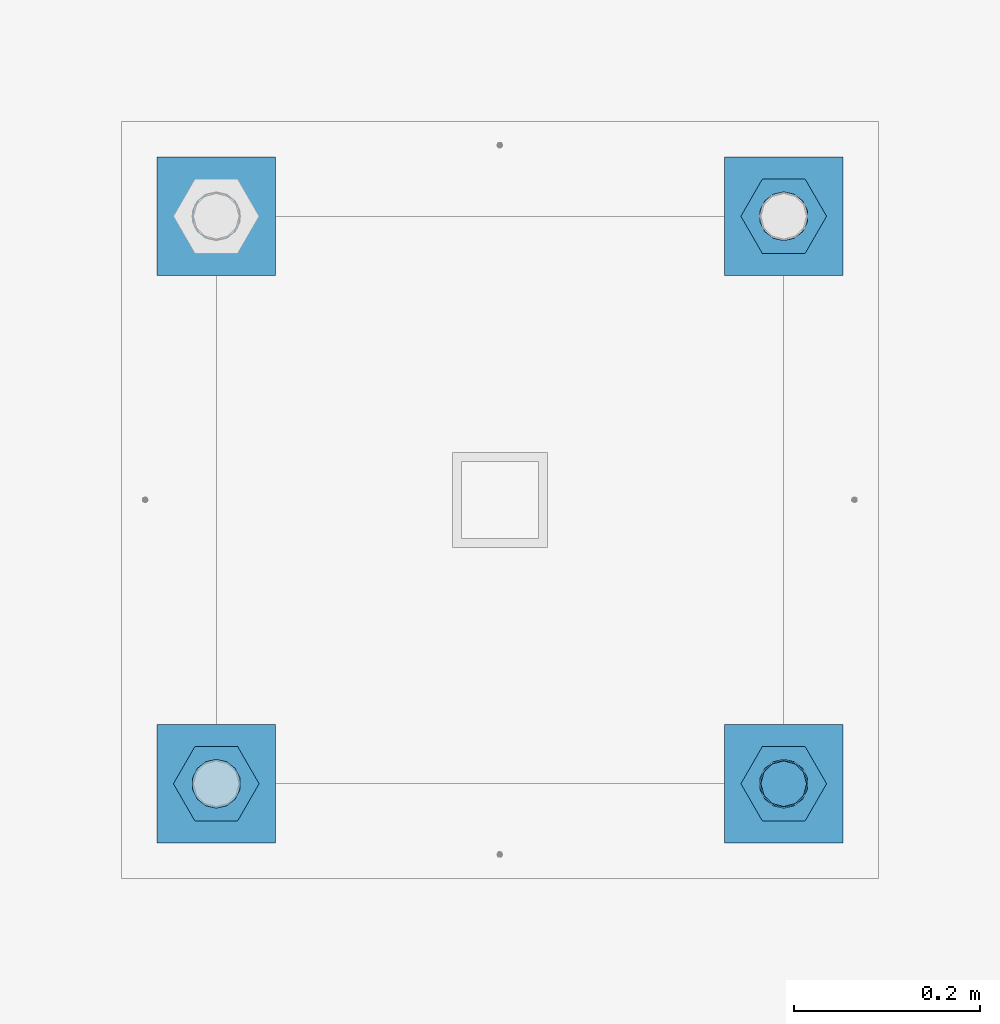
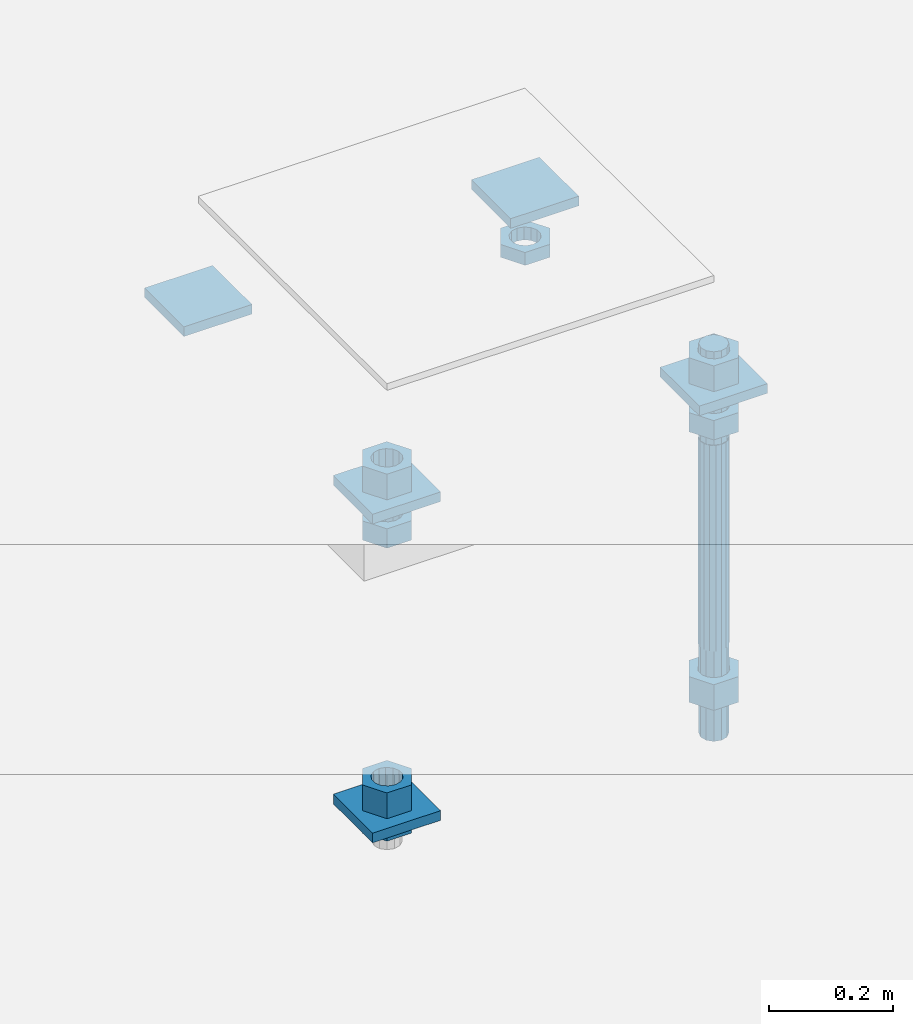
# One storey, part 2727 of 3843: 14 beams, 1 element without a shape of its own.
"""IFC2X3 building model written with IfcOpenShell, lengths in millimetres."""

from ifc_helpers import new_model, si_unit, frame, origin_with_axes, place, context, subcontext, project, spatial, faceted_brep, material, type_object, element, aggregate, save


model = new_model("IFC2X3")

# Units and contexts
model_context = context("Model", 3, precision=1e-05, world=origin_with_axes())
body_context = subcontext(model_context, "Body", "Model", "MODEL_VIEW")
ifc_project = project(units=[si_unit("LENGTHUNIT", "METRE", prefix="MILLI"), si_unit("AREAUNIT", "SQUARE_METRE"), si_unit("VOLUMEUNIT", "CUBIC_METRE"), si_unit("MASSUNIT", "GRAM", prefix="KILO"), si_unit("TIMEUNIT", "SECOND"), si_unit("PLANEANGLEUNIT", "RADIAN"), si_unit("SOLIDANGLEUNIT", "STERADIAN"), si_unit("THERMODYNAMICTEMPERATUREUNIT", "DEGREE_CELSIUS"), si_unit("LUMINOUSINTENSITYUNIT", "LUMEN")], contexts=[model_context])

# Site, building, storey
site_placement = place(None, origin_with_axes())
site = spatial("IfcSite", under=ifc_project, at=site_placement, CompositionType="ELEMENT")
building_placement = place(site_placement, origin_with_axes())
building = spatial("IfcBuilding", under=site, at=building_placement, Name="Undefined", CompositionType="ELEMENT")
storey_placement = place(building_placement, origin_with_axes())
storey = spatial("IfcBuildingStorey", under=building, at=storey_placement, Name="Undefined", CompositionType="ELEMENT", Elevation=0.0)

# Assembly, beams
assembly_placement = place(storey_placement, origin_with_axes())
assembly = element("IfcElementAssembly", 1, at=assembly_placement, inside=storey, Name="TEMPLATE", AssemblyPlace="NOTDEFINED", PredefinedType="RIGID_FRAME")
ifc_material_1 = material(Name="STEEL/A36")
beam_type_1 = type_object("IfcBeamType", PredefinedType="NOTDEFINED")
beam_1_placement = place(assembly_placement, frame((111734.6, 35750.5000015259, 29873.575), z_axis=(1.0, 0.0, 0.0), x_axis=(0.0, 1.0, 0.0)))
beam_1 = element("IfcBeam", 2, at=beam_1_placement, type_object=beam_type_1, material=ifc_material_1, Name="WASHER_PLATE", context=body_context, shape_type="Brep", body=[
    faceted_brep([(0.0, 9.52500000000146, -63.5), (0.0, 9.52500000000146, 63.5), (127.0, 9.52500000000146, 63.5), (127.0, 9.52500000000146, -63.5), (0.0, -9.52500000000146, 63.5), (127.0, -9.52500000000146, 63.5), (0.0, -9.52500000000146, -63.5), (127.0, -9.52500000000146, -63.5)], [[[0, 1, 2, 3]], [[1, 4, 5, 2]], [[4, 6, 7, 5]], [[6, 0, 3, 7]], [[5, 7, 3, 2]], [[6, 4, 1, 0]]]),
])
beam_2_placement = place(assembly_placement, frame((112344.2, 35750.5000015259, 29873.575), z_axis=(1.0, 0.0, 0.0), x_axis=(0.0, 1.0, 0.0)))
beam_2 = element("IfcBeam", 3, at=beam_2_placement, type_object=beam_type_1, material=ifc_material_1, Name="WASHER_PLATE", context=body_context, shape_type="Brep", body=[
    faceted_brep([(0.0, 9.52500000000146, -63.5), (0.0, 9.52500000000146, 63.5), (127.0, 9.52500000000146, 63.5), (127.0, 9.52500000000146, -63.5), (0.0, -9.52500000000146, 63.5), (127.0, -9.52500000000146, 63.5), (0.0, -9.52500000000146, -63.5), (127.0, -9.52500000000146, -63.5)], [[[0, 1, 2, 3]], [[1, 4, 5, 2]], [[4, 6, 7, 5]], [[6, 0, 3, 7]], [[5, 7, 3, 2]], [[6, 4, 1, 0]]]),
])
beam_3_placement = place(assembly_placement, frame((111734.6, 36360.1000015259, 29873.575), z_axis=(1.0, 0.0, 0.0), x_axis=(0.0, 1.0, 0.0)))
beam_3 = element("IfcBeam", 4, at=beam_3_placement, type_object=beam_type_1, material=ifc_material_1, Name="WASHER_PLATE", context=body_context, shape_type="Brep", body=[
    faceted_brep([(0.0, 9.52500000000146, -63.5), (0.0, 9.52500000000146, 63.5), (127.0, 9.52500000000146, 63.5), (127.0, 9.52500000000146, -63.5), (0.0, -9.52500000000146, 63.5), (127.0, -9.52500000000146, 63.5), (0.0, -9.52500000000146, -63.5), (127.0, -9.52500000000146, -63.5)], [[[0, 1, 2, 3]], [[1, 4, 5, 2]], [[4, 6, 7, 5]], [[6, 0, 3, 7]], [[5, 7, 3, 2]], [[6, 4, 1, 0]]]),
])
beam_4_placement = place(assembly_placement, frame((112344.2, 36360.1000015259, 29873.575), z_axis=(1.0, 0.0, 0.0), x_axis=(0.0, 1.0, 0.0)))
beam_4 = element("IfcBeam", 5, at=beam_4_placement, type_object=beam_type_1, material=ifc_material_1, Name="WASHER_PLATE", context=body_context, shape_type="Brep", body=[
    faceted_brep([(0.0, 9.52500000000146, -63.5), (0.0, 9.52500000000146, 63.5), (127.0, 9.52500000000146, 63.5), (127.0, 9.52500000000146, -63.5), (0.0, -9.52500000000146, 63.5), (127.0, -9.52500000000146, 63.5), (0.0, -9.52500000000146, -63.5), (127.0, -9.52500000000146, -63.5)], [[[0, 1, 2, 3]], [[1, 4, 5, 2]], [[4, 6, 7, 5]], [[6, 0, 3, 7]], [[5, 7, 3, 2]], [[6, 4, 1, 0]]]),
])
beam_5_placement = place(assembly_placement, frame((111734.6, 35750.5000015259, 29244.925), z_axis=(1.0, 0.0, 0.0), x_axis=(0.0, 1.0, 0.0)))
beam_5 = element("IfcBeam", 6, at=beam_5_placement, type_object=beam_type_1, material=ifc_material_1, Name="WASHER_PLATE", context=body_context, shape_type="Brep", body=[
    faceted_brep([(0.0, 9.52500000000146, -63.5), (0.0, 9.52500000000146, 63.5), (127.0, 9.52500000000146, 63.5), (127.0, 9.52500000000146, -63.5), (0.0, -9.52500000000146, 63.5), (127.0, -9.52500000000146, 63.5), (0.0, -9.52500000000146, -63.5), (127.0, -9.52500000000146, -63.5)], [[[0, 1, 2, 3]], [[1, 4, 5, 2]], [[4, 6, 7, 5]], [[6, 0, 3, 7]], [[5, 7, 3, 2]], [[6, 4, 1, 0]]]),
])
beam_type_2 = type_object("IfcBeamType", Name="2_HALF_NUT", PredefinedType="NOTDEFINED")
beam_6_placement = place(assembly_placement, frame((112344.2, 36423.6000015259, 29787.85), z_axis=(0.0, 1.0, 0.0), x_axis=(0.0, 0.0, -1.0)))
beam_6 = element("IfcBeam", 7, at=beam_6_placement, type_object=beam_type_2, material=ifc_material_1, Name="NUT", ObjectType="2_HALF_NUT", context=body_context, shape_type="Brep", body=[
    faceted_brep([(0.0, -46.0369987487793, 0.0), (0.0, -23.0184993743896, -39.869213104248), (25.4000000000015, -23.0184993743896, -39.869213104248), (25.4000000000015, -46.0369987487793, 0.0), (0.0, 23.0184993743896, -39.869213104248), (25.4000000000015, 23.0184993743896, -39.869213104248), (0.0, 46.0369987487793, 0.0), (25.4000000000015, 46.0369987487793, 0.0), (0.0, 23.0184993743896, 39.869213104248), (25.4000000000015, 23.0184993743896, 39.869213104248), (0.0, -23.0184993743896, 39.869213104248), (25.4000000000015, -23.0184993743896, 39.869213104248), (0.0, 0.0, 26.1940002441406), (0.0, 11.3650617044477, 23.5999013092805), (25.4000000000015, 11.3650617044477, 23.5999013092805), (25.4000000000015, 0.0, 26.1940002441406), (0.0, 20.4791109456419, 16.3316083006721), (25.4000000000015, 20.4791109456419, 16.3316083006721), (0.0, 25.5370200498292, 5.82867859874386), (25.4000000000015, 25.5370200498292, 5.82867859874386), (0.0, 25.5370200498292, -5.82867859874386), (25.4000000000015, 25.5370200498292, -5.82867859874386), (0.0, 20.4791109456419, -16.3316083006721), (25.4000000000015, 20.4791109456419, -16.3316083006721), (0.0, 11.3650617044477, -23.5999013092805), (25.4000000000015, 11.3650617044477, -23.5999013092805), (0.0, 0.0, -26.1940002441406), (25.4000000000015, 0.0, -26.1940002441406), (0.0, -11.3650617044477, -23.5999013092805), (25.4000000000015, -11.3650617044477, -23.5999013092805), (0.0, -20.4791109456419, -16.3316083006721), (25.4000000000015, -20.4791109456419, -16.3316083006721), (0.0, -25.5370200498292, -5.82867859874386), (25.4000000000015, -25.5370200498292, -5.82867859874386), (0.0, -25.5370200498292, 5.82867859874386), (25.4000000000015, -25.5370200498292, 5.82867859874386), (0.0, -20.4791109456419, 16.3316083006721), (25.4000000000015, -20.4791109456419, 16.3316083006721), (0.0, -11.3650617044477, 23.5999013092805), (25.4000000000015, -11.3650617044477, 23.5999013092805)], [[[0, 1, 2, 3]], [[1, 4, 5, 2]], [[4, 6, 7, 5]], [[6, 8, 9, 7]], [[8, 10, 11, 9]], [[10, 0, 3, 11]], [[12, 13, 14, 15]], [[13, 16, 17, 14]], [[16, 18, 19, 17]], [[18, 20, 21, 19]], [[20, 22, 23, 21]], [[22, 24, 25, 23]], [[24, 26, 27, 25]], [[26, 28, 29, 27]], [[28, 30, 31, 29]], [[30, 32, 33, 31]], [[32, 34, 35, 33]], [[34, 36, 37, 35]], [[36, 38, 39, 37]], [[38, 12, 15, 39]], [[5, 7, 9, 11, 3, 2], [17, 19, 21, 23, 25, 27, 29, 31, 33, 35, 37, 39, 15, 14]], [[10, 8, 6, 4, 1, 0], [38, 36, 34, 32, 30, 28, 26, 24, 22, 20, 18, 16, 13, 12]]]),
])
beam_7_placement = place(assembly_placement, frame((111734.6, 35814.0000015259, 29235.4), z_axis=(0.0, 1.0, 0.0), x_axis=(0.0, 0.0, -1.0)))
beam_7 = element("IfcBeam", 8, at=beam_7_placement, type_object=beam_type_2, material=ifc_material_1, Name="NUT", ObjectType="2_HALF_NUT", context=body_context, shape_type="Brep", body=[
    faceted_brep([(0.0, -46.0369987487793, 0.0), (0.0, -23.0184993743896, -39.869213104248), (25.4000000000015, -23.0184993743896, -39.869213104248), (25.4000000000015, -46.0369987487793, 0.0), (0.0, 23.0184993743896, -39.869213104248), (25.4000000000015, 23.0184993743896, -39.869213104248), (0.0, 46.0369987487793, 0.0), (25.4000000000015, 46.0369987487793, 0.0), (0.0, 23.0184993743896, 39.869213104248), (25.4000000000015, 23.0184993743896, 39.869213104248), (0.0, -23.0184993743896, 39.869213104248), (25.4000000000015, -23.0184993743896, 39.869213104248), (0.0, 0.0, 26.1940002441406), (0.0, 11.3650617044477, 23.5999013092805), (25.4000000000015, 11.3650617044477, 23.5999013092805), (25.4000000000015, 0.0, 26.1940002441406), (0.0, 20.4791109456419, 16.3316083006721), (25.4000000000015, 20.4791109456419, 16.3316083006721), (0.0, 25.5370200498292, 5.82867859874386), (25.4000000000015, 25.5370200498292, 5.82867859874386), (0.0, 25.5370200498292, -5.82867859874386), (25.4000000000015, 25.5370200498292, -5.82867859874386), (0.0, 20.4791109456419, -16.3316083006721), (25.4000000000015, 20.4791109456419, -16.3316083006721), (0.0, 11.3650617044477, -23.5999013092805), (25.4000000000015, 11.3650617044477, -23.5999013092805), (0.0, 0.0, -26.1940002441406), (25.4000000000015, 0.0, -26.1940002441406), (0.0, -11.3650617044477, -23.5999013092805), (25.4000000000015, -11.3650617044477, -23.5999013092805), (0.0, -20.4791109456419, -16.3316083006721), (25.4000000000015, -20.4791109456419, -16.3316083006721), (0.0, -25.5370200498292, -5.82867859874386), (25.4000000000015, -25.5370200498292, -5.82867859874386), (0.0, -25.5370200498292, 5.82867859874386), (25.4000000000015, -25.5370200498292, 5.82867859874386), (0.0, -20.4791109456419, 16.3316083006721), (25.4000000000015, -20.4791109456419, 16.3316083006721), (0.0, -11.3650617044477, 23.5999013092805), (25.4000000000015, -11.3650617044477, 23.5999013092805)], [[[0, 1, 2, 3]], [[1, 4, 5, 2]], [[4, 6, 7, 5]], [[6, 8, 9, 7]], [[8, 10, 11, 9]], [[10, 0, 3, 11]], [[12, 13, 14, 15]], [[13, 16, 17, 14]], [[16, 18, 19, 17]], [[18, 20, 21, 19]], [[20, 22, 23, 21]], [[22, 24, 25, 23]], [[24, 26, 27, 25]], [[26, 28, 29, 27]], [[28, 30, 31, 29]], [[30, 32, 33, 31]], [[32, 34, 35, 33]], [[34, 36, 37, 35]], [[36, 38, 39, 37]], [[38, 12, 15, 39]], [[5, 7, 9, 11, 3, 2], [17, 19, 21, 23, 25, 27, 29, 31, 33, 35, 37, 39, 15, 14]], [[10, 8, 6, 4, 1, 0], [38, 36, 34, 32, 30, 28, 26, 24, 22, 20, 18, 16, 13, 12]]]),
])
beam_type_3 = type_object("IfcBeamType", Name="2_HEAVY_HEX_NUT", PredefinedType="NOTDEFINED")
beam_8_placement = place(assembly_placement, frame((111734.6, 35814.0000015259, 29825.95), z_axis=(0.0, 1.0, 0.0), x_axis=(0.0, 0.0, -1.0)))
beam_8 = element("IfcBeam", 9, at=beam_8_placement, type_object=beam_type_3, material=ifc_material_1, Name="NUT", ObjectType="2_HEAVY_HEX_NUT", context=body_context, shape_type="Brep", body=[
    faceted_brep([(0.0, -46.0369987487793, 0.0), (0.0, -23.0184993743896, -39.869213104248), (38.0999999999985, -23.0184993743896, -39.869213104248), (38.0999999999985, -46.0369987487793, 0.0), (0.0, 23.0184993743896, -39.869213104248), (38.0999999999985, 23.0184993743896, -39.869213104248), (0.0, 46.0369987487793, 0.0), (38.0999999999985, 46.0369987487793, 0.0), (0.0, 23.0184993743896, 39.869213104248), (38.0999999999985, 23.0184993743896, 39.869213104248), (0.0, -23.0184993743896, 39.869213104248), (38.0999999999985, -23.0184993743896, 39.869213104248), (0.0, 0.0, 26.1940002441406), (0.0, 11.3650617044477, 23.5999013092805), (38.0999999999985, 11.3650617044477, 23.5999013092805), (38.0999999999985, 0.0, 26.1940002441406), (0.0, 20.4791109456419, 16.3316083006721), (38.0999999999985, 20.4791109456419, 16.3316083006721), (0.0, 25.5370200498292, 5.82867859874386), (38.0999999999985, 25.5370200498292, 5.82867859874386), (0.0, 25.5370200498292, -5.82867859874386), (38.0999999999985, 25.5370200498292, -5.82867859874386), (0.0, 20.4791109456419, -16.3316083006721), (38.0999999999985, 20.4791109456419, -16.3316083006721), (0.0, 11.3650617044477, -23.5999013092805), (38.0999999999985, 11.3650617044477, -23.5999013092805), (0.0, 0.0, -26.1940002441406), (38.0999999999985, 0.0, -26.1940002441406), (0.0, -11.3650617044477, -23.5999013092805), (38.0999999999985, -11.3650617044477, -23.5999013092805), (0.0, -20.4791109456419, -16.3316083006721), (38.0999999999985, -20.4791109456419, -16.3316083006721), (0.0, -25.5370200498292, -5.82867859874386), (38.0999999999985, -25.5370200498292, -5.82867859874386), (0.0, -25.5370200498292, 5.82867859874386), (38.0999999999985, -25.5370200498292, 5.82867859874386), (0.0, -20.4791109456419, 16.3316083006721), (38.0999999999985, -20.4791109456419, 16.3316083006721), (0.0, -11.3650617044477, 23.5999013092805), (38.0999999999985, -11.3650617044477, 23.5999013092805)], [[[0, 1, 2, 3]], [[1, 4, 5, 2]], [[4, 6, 7, 5]], [[6, 8, 9, 7]], [[8, 10, 11, 9]], [[10, 0, 3, 11]], [[12, 13, 14, 15]], [[13, 16, 17, 14]], [[16, 18, 19, 17]], [[18, 20, 21, 19]], [[20, 22, 23, 21]], [[22, 24, 25, 23]], [[24, 26, 27, 25]], [[26, 28, 29, 27]], [[28, 30, 31, 29]], [[30, 32, 33, 31]], [[32, 34, 35, 33]], [[34, 36, 37, 35]], [[36, 38, 39, 37]], [[38, 12, 15, 39]], [[5, 7, 9, 11, 3, 2], [17, 19, 21, 23, 25, 27, 29, 31, 33, 35, 37, 39, 15, 14]], [[10, 8, 6, 4, 1, 0], [38, 36, 34, 32, 30, 28, 26, 24, 22, 20, 18, 16, 13, 12]]]),
])
beam_9_placement = place(assembly_placement, frame((111734.6, 35814.0000015259, 29933.9), z_axis=(0.0, 1.0, 0.0), x_axis=(0.0, 0.0, -1.0)))
beam_9 = element("IfcBeam", 10, at=beam_9_placement, type_object=beam_type_3, material=ifc_material_1, Name="NUT", ObjectType="2_HEAVY_HEX_NUT", context=body_context, shape_type="Brep", body=[
    faceted_brep([(0.0, -46.0369987487793, 0.0), (0.0, -23.0184993743896, -39.869213104248), (50.7999999999993, -23.0184993743896, -39.869213104248), (50.7999999999993, -46.0369987487793, 0.0), (0.0, 23.0184993743896, -39.869213104248), (50.7999999999993, 23.0184993743896, -39.869213104248), (0.0, 46.0369987487793, 0.0), (50.7999999999993, 46.0369987487793, 0.0), (0.0, 23.0184993743896, 39.869213104248), (50.7999999999993, 23.0184993743896, 39.869213104248), (0.0, -23.0184993743896, 39.869213104248), (50.7999999999993, -23.0184993743896, 39.869213104248), (0.0, 0.0, 26.1940002441406), (0.0, 11.3650617044477, 23.5999013092805), (50.7999999999993, 11.3650617044477, 23.5999013092805), (50.7999999999993, 0.0, 26.1940002441406), (0.0, 20.4791109456419, 16.3316083006721), (50.7999999999993, 20.4791109456419, 16.3316083006721), (0.0, 25.5370200498292, 5.82867859874386), (50.7999999999993, 25.5370200498292, 5.82867859874386), (0.0, 25.5370200498292, -5.82867859874386), (50.7999999999993, 25.5370200498292, -5.82867859874386), (0.0, 20.4791109456419, -16.3316083006721), (50.7999999999993, 20.4791109456419, -16.3316083006721), (0.0, 11.3650617044477, -23.5999013092805), (50.7999999999993, 11.3650617044477, -23.5999013092805), (0.0, 0.0, -26.1940002441406), (50.7999999999993, 0.0, -26.1940002441406), (0.0, -11.3650617044477, -23.5999013092805), (50.7999999999993, -11.3650617044477, -23.5999013092805), (0.0, -20.4791109456419, -16.3316083006721), (50.7999999999993, -20.4791109456419, -16.3316083006721), (0.0, -25.5370200498292, -5.82867859874386), (50.7999999999993, -25.5370200498292, -5.82867859874386), (0.0, -25.5370200498292, 5.82867859874386), (50.7999999999993, -25.5370200498292, 5.82867859874386), (0.0, -20.4791109456419, 16.3316083006721), (50.7999999999993, -20.4791109456419, 16.3316083006721), (0.0, -11.3650617044477, 23.5999013092805), (50.7999999999993, -11.3650617044477, 23.5999013092805)], [[[0, 1, 2, 3]], [[1, 4, 5, 2]], [[4, 6, 7, 5]], [[6, 8, 9, 7]], [[8, 10, 11, 9]], [[10, 0, 3, 11]], [[12, 13, 14, 15]], [[13, 16, 17, 14]], [[16, 18, 19, 17]], [[18, 20, 21, 19]], [[20, 22, 23, 21]], [[22, 24, 25, 23]], [[24, 26, 27, 25]], [[26, 28, 29, 27]], [[28, 30, 31, 29]], [[30, 32, 33, 31]], [[32, 34, 35, 33]], [[34, 36, 37, 35]], [[36, 38, 39, 37]], [[38, 12, 15, 39]], [[5, 7, 9, 11, 3, 2], [17, 19, 21, 23, 25, 27, 29, 31, 33, 35, 37, 39, 15, 14]], [[10, 8, 6, 4, 1, 0], [38, 36, 34, 32, 30, 28, 26, 24, 22, 20, 18, 16, 13, 12]]]),
])
beam_10_placement = place(assembly_placement, frame((111734.6, 35814.0000015259, 29305.25), z_axis=(0.0, 1.0, 0.0), x_axis=(0.0, 0.0, -1.0)))
beam_10 = element("IfcBeam", 11, at=beam_10_placement, type_object=beam_type_3, material=ifc_material_1, Name="NUT", ObjectType="2_HEAVY_HEX_NUT", context=body_context, shape_type="Brep", body=[
    faceted_brep([(0.0, -46.0369987487793, 0.0), (0.0, -23.0184993743896, -39.869213104248), (50.7999999999993, -23.0184993743896, -39.869213104248), (50.7999999999993, -46.0369987487793, 0.0), (0.0, 23.0184993743896, -39.869213104248), (50.7999999999993, 23.0184993743896, -39.869213104248), (0.0, 46.0369987487793, 0.0), (50.7999999999993, 46.0369987487793, 0.0), (0.0, 23.0184993743896, 39.869213104248), (50.7999999999993, 23.0184993743896, 39.869213104248), (0.0, -23.0184993743896, 39.869213104248), (50.7999999999993, -23.0184993743896, 39.869213104248), (0.0, 0.0, 26.1940002441406), (0.0, 11.3650617044477, 23.5999013092805), (50.7999999999993, 11.3650617044477, 23.5999013092805), (50.7999999999993, 0.0, 26.1940002441406), (0.0, 20.4791109456419, 16.3316083006721), (50.7999999999993, 20.4791109456419, 16.3316083006721), (0.0, 25.5370200498292, 5.82867859874386), (50.7999999999993, 25.5370200498292, 5.82867859874386), (0.0, 25.5370200498292, -5.82867859874386), (50.7999999999993, 25.5370200498292, -5.82867859874386), (0.0, 20.4791109456419, -16.3316083006721), (50.7999999999993, 20.4791109456419, -16.3316083006721), (0.0, 11.3650617044477, -23.5999013092805), (50.7999999999993, 11.3650617044477, -23.5999013092805), (0.0, 0.0, -26.1940002441406), (50.7999999999993, 0.0, -26.1940002441406), (0.0, -11.3650617044477, -23.5999013092805), (50.7999999999993, -11.3650617044477, -23.5999013092805), (0.0, -20.4791109456419, -16.3316083006721), (50.7999999999993, -20.4791109456419, -16.3316083006721), (0.0, -25.5370200498292, -5.82867859874386), (50.7999999999993, -25.5370200498292, -5.82867859874386), (0.0, -25.5370200498292, 5.82867859874386), (50.7999999999993, -25.5370200498292, 5.82867859874386), (0.0, -20.4791109456419, 16.3316083006721), (50.7999999999993, -20.4791109456419, 16.3316083006721), (0.0, -11.3650617044477, 23.5999013092805), (50.7999999999993, -11.3650617044477, 23.5999013092805)], [[[0, 1, 2, 3]], [[1, 4, 5, 2]], [[4, 6, 7, 5]], [[6, 8, 9, 7]], [[8, 10, 11, 9]], [[10, 0, 3, 11]], [[12, 13, 14, 15]], [[13, 16, 17, 14]], [[16, 18, 19, 17]], [[18, 20, 21, 19]], [[20, 22, 23, 21]], [[22, 24, 25, 23]], [[24, 26, 27, 25]], [[26, 28, 29, 27]], [[28, 30, 31, 29]], [[30, 32, 33, 31]], [[32, 34, 35, 33]], [[34, 36, 37, 35]], [[36, 38, 39, 37]], [[38, 12, 15, 39]], [[5, 7, 9, 11, 3, 2], [17, 19, 21, 23, 25, 27, 29, 31, 33, 35, 37, 39, 15, 14]], [[10, 8, 6, 4, 1, 0], [38, 36, 34, 32, 30, 28, 26, 24, 22, 20, 18, 16, 13, 12]]]),
])
beam_11_placement = place(assembly_placement, frame((112344.2, 35814.0000015259, 29825.95), z_axis=(0.0, 1.0, 0.0), x_axis=(0.0, 0.0, -1.0)))
beam_11 = element("IfcBeam", 12, at=beam_11_placement, type_object=beam_type_3, material=ifc_material_1, Name="NUT", ObjectType="2_HEAVY_HEX_NUT", context=body_context, shape_type="Brep", body=[
    faceted_brep([(0.0, -46.0369987487793, 0.0), (0.0, -23.0184993743896, -39.869213104248), (38.0999999999985, -23.0184993743896, -39.869213104248), (38.0999999999985, -46.0369987487793, 0.0), (0.0, 23.0184993743896, -39.869213104248), (38.0999999999985, 23.0184993743896, -39.869213104248), (0.0, 46.0369987487793, 0.0), (38.0999999999985, 46.0369987487793, 0.0), (0.0, 23.0184993743896, 39.869213104248), (38.0999999999985, 23.0184993743896, 39.869213104248), (0.0, -23.0184993743896, 39.869213104248), (38.0999999999985, -23.0184993743896, 39.869213104248), (0.0, 0.0, 26.1940002441406), (0.0, 11.3650617044477, 23.5999013092805), (38.0999999999985, 11.3650617044477, 23.5999013092805), (38.0999999999985, 0.0, 26.1940002441406), (0.0, 20.4791109456419, 16.3316083006721), (38.0999999999985, 20.4791109456419, 16.3316083006721), (0.0, 25.5370200498292, 5.82867859874386), (38.0999999999985, 25.5370200498292, 5.82867859874386), (0.0, 25.5370200498292, -5.82867859874386), (38.0999999999985, 25.5370200498292, -5.82867859874386), (0.0, 20.4791109456419, -16.3316083006721), (38.0999999999985, 20.4791109456419, -16.3316083006721), (0.0, 11.3650617044477, -23.5999013092805), (38.0999999999985, 11.3650617044477, -23.5999013092805), (0.0, 0.0, -26.1940002441406), (38.0999999999985, 0.0, -26.1940002441406), (0.0, -11.3650617044477, -23.5999013092805), (38.0999999999985, -11.3650617044477, -23.5999013092805), (0.0, -20.4791109456419, -16.3316083006721), (38.0999999999985, -20.4791109456419, -16.3316083006721), (0.0, -25.5370200498292, -5.82867859874386), (38.0999999999985, -25.5370200498292, -5.82867859874386), (0.0, -25.5370200498292, 5.82867859874386), (38.0999999999985, -25.5370200498292, 5.82867859874386), (0.0, -20.4791109456419, 16.3316083006721), (38.0999999999985, -20.4791109456419, 16.3316083006721), (0.0, -11.3650617044477, 23.5999013092805), (38.0999999999985, -11.3650617044477, 23.5999013092805)], [[[0, 1, 2, 3]], [[1, 4, 5, 2]], [[4, 6, 7, 5]], [[6, 8, 9, 7]], [[8, 10, 11, 9]], [[10, 0, 3, 11]], [[12, 13, 14, 15]], [[13, 16, 17, 14]], [[16, 18, 19, 17]], [[18, 20, 21, 19]], [[20, 22, 23, 21]], [[22, 24, 25, 23]], [[24, 26, 27, 25]], [[26, 28, 29, 27]], [[28, 30, 31, 29]], [[30, 32, 33, 31]], [[32, 34, 35, 33]], [[34, 36, 37, 35]], [[36, 38, 39, 37]], [[38, 12, 15, 39]], [[5, 7, 9, 11, 3, 2], [17, 19, 21, 23, 25, 27, 29, 31, 33, 35, 37, 39, 15, 14]], [[10, 8, 6, 4, 1, 0], [38, 36, 34, 32, 30, 28, 26, 24, 22, 20, 18, 16, 13, 12]]]),
])
beam_12_placement = place(assembly_placement, frame((112344.2, 35814.0000015259, 29933.9), z_axis=(0.0, 1.0, 0.0), x_axis=(0.0, 0.0, -1.0)))
beam_12 = element("IfcBeam", 13, at=beam_12_placement, type_object=beam_type_3, material=ifc_material_1, Name="NUT", ObjectType="2_HEAVY_HEX_NUT", context=body_context, shape_type="Brep", body=[
    faceted_brep([(0.0, -46.0369987487793, 0.0), (0.0, -23.0184993743896, -39.869213104248), (50.7999999999993, -23.0184993743896, -39.869213104248), (50.7999999999993, -46.0369987487793, 0.0), (0.0, 23.0184993743896, -39.869213104248), (50.7999999999993, 23.0184993743896, -39.869213104248), (0.0, 46.0369987487793, 0.0), (50.7999999999993, 46.0369987487793, 0.0), (0.0, 23.0184993743896, 39.869213104248), (50.7999999999993, 23.0184993743896, 39.869213104248), (0.0, -23.0184993743896, 39.869213104248), (50.7999999999993, -23.0184993743896, 39.869213104248), (0.0, 0.0, 26.1940002441406), (0.0, 11.3650617044477, 23.5999013092805), (50.7999999999993, 11.3650617044477, 23.5999013092805), (50.7999999999993, 0.0, 26.1940002441406), (0.0, 20.4791109456419, 16.3316083006721), (50.7999999999993, 20.4791109456419, 16.3316083006721), (0.0, 25.5370200498292, 5.82867859874386), (50.7999999999993, 25.5370200498292, 5.82867859874386), (0.0, 25.5370200498292, -5.82867859874386), (50.7999999999993, 25.5370200498292, -5.82867859874386), (0.0, 20.4791109456419, -16.3316083006721), (50.7999999999993, 20.4791109456419, -16.3316083006721), (0.0, 11.3650617044477, -23.5999013092805), (50.7999999999993, 11.3650617044477, -23.5999013092805), (0.0, 0.0, -26.1940002441406), (50.7999999999993, 0.0, -26.1940002441406), (0.0, -11.3650617044477, -23.5999013092805), (50.7999999999993, -11.3650617044477, -23.5999013092805), (0.0, -20.4791109456419, -16.3316083006721), (50.7999999999993, -20.4791109456419, -16.3316083006721), (0.0, -25.5370200498292, -5.82867859874386), (50.7999999999993, -25.5370200498292, -5.82867859874386), (0.0, -25.5370200498292, 5.82867859874386), (50.7999999999993, -25.5370200498292, 5.82867859874386), (0.0, -20.4791109456419, 16.3316083006721), (50.7999999999993, -20.4791109456419, 16.3316083006721), (0.0, -11.3650617044477, 23.5999013092805), (50.7999999999993, -11.3650617044477, 23.5999013092805)], [[[0, 1, 2, 3]], [[1, 4, 5, 2]], [[4, 6, 7, 5]], [[6, 8, 9, 7]], [[8, 10, 11, 9]], [[10, 0, 3, 11]], [[12, 13, 14, 15]], [[13, 16, 17, 14]], [[16, 18, 19, 17]], [[18, 20, 21, 19]], [[20, 22, 23, 21]], [[22, 24, 25, 23]], [[24, 26, 27, 25]], [[26, 28, 29, 27]], [[28, 30, 31, 29]], [[30, 32, 33, 31]], [[32, 34, 35, 33]], [[34, 36, 37, 35]], [[36, 38, 39, 37]], [[38, 12, 15, 39]], [[5, 7, 9, 11, 3, 2], [17, 19, 21, 23, 25, 27, 29, 31, 33, 35, 37, 39, 15, 14]], [[10, 8, 6, 4, 1, 0], [38, 36, 34, 32, 30, 28, 26, 24, 22, 20, 18, 16, 13, 12]]]),
])
beam_13_placement = place(assembly_placement, frame((112344.2, 35814.0000015259, 29305.25), z_axis=(0.0, 1.0, 0.0), x_axis=(0.0, 0.0, -1.0)))
beam_13 = element("IfcBeam", 14, at=beam_13_placement, type_object=beam_type_3, material=ifc_material_1, Name="NUT", ObjectType="2_HEAVY_HEX_NUT", context=body_context, shape_type="Brep", body=[
    faceted_brep([(0.0, -46.0369987487793, 0.0), (0.0, -23.0184993743896, -39.869213104248), (50.7999999999993, -23.0184993743896, -39.869213104248), (50.7999999999993, -46.0369987487793, 0.0), (0.0, 23.0184993743896, -39.869213104248), (50.7999999999993, 23.0184993743896, -39.869213104248), (0.0, 46.0369987487793, 0.0), (50.7999999999993, 46.0369987487793, 0.0), (0.0, 23.0184993743896, 39.869213104248), (50.7999999999993, 23.0184993743896, 39.869213104248), (0.0, -23.0184993743896, 39.869213104248), (50.7999999999993, -23.0184993743896, 39.869213104248), (0.0, 0.0, 26.1940002441406), (0.0, 11.3650617044477, 23.5999013092805), (50.7999999999993, 11.3650617044477, 23.5999013092805), (50.7999999999993, 0.0, 26.1940002441406), (0.0, 20.4791109456419, 16.3316083006721), (50.7999999999993, 20.4791109456419, 16.3316083006721), (0.0, 25.5370200498292, 5.82867859874386), (50.7999999999993, 25.5370200498292, 5.82867859874386), (0.0, 25.5370200498292, -5.82867859874386), (50.7999999999993, 25.5370200498292, -5.82867859874386), (0.0, 20.4791109456419, -16.3316083006721), (50.7999999999993, 20.4791109456419, -16.3316083006721), (0.0, 11.3650617044477, -23.5999013092805), (50.7999999999993, 11.3650617044477, -23.5999013092805), (0.0, 0.0, -26.1940002441406), (50.7999999999993, 0.0, -26.1940002441406), (0.0, -11.3650617044477, -23.5999013092805), (50.7999999999993, -11.3650617044477, -23.5999013092805), (0.0, -20.4791109456419, -16.3316083006721), (50.7999999999993, -20.4791109456419, -16.3316083006721), (0.0, -25.5370200498292, -5.82867859874386), (50.7999999999993, -25.5370200498292, -5.82867859874386), (0.0, -25.5370200498292, 5.82867859874386), (50.7999999999993, -25.5370200498292, 5.82867859874386), (0.0, -20.4791109456419, 16.3316083006721), (50.7999999999993, -20.4791109456419, 16.3316083006721), (0.0, -11.3650617044477, 23.5999013092805), (50.7999999999993, -11.3650617044477, 23.5999013092805)], [[[0, 1, 2, 3]], [[1, 4, 5, 2]], [[4, 6, 7, 5]], [[6, 8, 9, 7]], [[8, 10, 11, 9]], [[10, 0, 3, 11]], [[12, 13, 14, 15]], [[13, 16, 17, 14]], [[16, 18, 19, 17]], [[18, 20, 21, 19]], [[20, 22, 23, 21]], [[22, 24, 25, 23]], [[24, 26, 27, 25]], [[26, 28, 29, 27]], [[28, 30, 31, 29]], [[30, 32, 33, 31]], [[32, 34, 35, 33]], [[34, 36, 37, 35]], [[36, 38, 39, 37]], [[38, 12, 15, 39]], [[5, 7, 9, 11, 3, 2], [17, 19, 21, 23, 25, 27, 29, 31, 33, 35, 37, 39, 15, 14]], [[10, 8, 6, 4, 1, 0], [38, 36, 34, 32, 30, 28, 26, 24, 22, 20, 18, 16, 13, 12]]]),
])
ifc_material_2 = material()
beam_type_4 = type_object("IfcBeamType", PredefinedType="NOTDEFINED")
beam_14_placement = place(assembly_placement, frame((112344.2, 35814.0000015259, 29762.45), z_axis=(0.0, 1.0, 0.0), x_axis=(0.0, 0.0, -1.0)))
beam_14 = element("IfcBeam", 15, at=beam_14_placement, type_object=beam_type_4, material=ifc_material_2, Name="ANCHOR_ROD", context=body_context, shape_type="Brep", body=[
    faceted_brep([(-184.150000000001, -21.217622392709, 12.25), (-184.150000000001, -12.2499999999854, 21.2176223927163), (-184.150000000001, 1.45519152283669e-11, 24.5), (-184.150000000001, 12.2500000000146, 21.2176223927163), (-184.150000000001, 21.2176223927381, 12.25), (-184.150000000001, 24.5000000000146, 0.0), (-184.150000000001, 21.2176223927381, -12.25), (-184.150000000001, 12.2500000000146, -21.2176223927163), (-184.150000000001, 1.45519152283669e-11, -24.5), (-184.150000000001, -12.2499999999854, -21.2176223927163), (-184.150000000001, -21.217622392709, -12.25), (-184.150000000001, -24.4999999999854, 0.0), (0.0, 24.5000000000146, 0.0), (0.0, 21.2176223927381, -12.25), (0.0, 12.2500000000146, -21.2176223927163), (0.0, 1.45519152283669e-11, -24.5), (0.0, -12.2499999999854, -21.2176223927163), (0.0, -21.217622392709, -12.25), (0.0, -24.4999999999854, 0.0), (0.0, -21.217622392709, 12.25), (0.0, -12.2499999999854, 21.2176223927163), (0.0, 1.45519152283669e-11, 24.5), (0.0, 12.2500000000146, 21.2176223927163), (0.0, 21.2176223927381, 12.25), (0.0, -23.4665401257807, 9.72015918207035), (0.0, -17.9605122421344, 17.9605122421417), (0.0, -9.72015918207762, 23.466540125788), (0.0, 0.0, 25.4000000000015), (0.0, 9.72015918207762, 23.466540125788), (0.0, 17.9605122421344, 17.9605122421417), (0.0, 23.4665401257807, 9.72015918207035), (0.0, 25.3999996185303, 0.0), (0.0, 23.4665401257807, -9.72015918207035), (0.0, 17.9605122421344, -17.9605122421417), (0.0, 9.72015918207762, -23.466540125788), (0.0, 0.0, -25.4000000000015), (0.0, -9.72015918207762, -23.466540125788), (0.0, -17.9605122421344, -17.9605122421417), (0.0, -23.4665401257807, -9.72015918207035), (0.0, -25.3999996185303, 0.0), (406.399999999998, -25.3999999999942, 0.0), (406.399999999998, -23.4665401257807, 9.72015918207035), (406.399999999998, -17.9605122421344, 17.9605122421417), (406.399999999998, -9.72015918207762, 23.466540125788), (406.399999999998, 0.0, 25.4000000000015), (406.399999999998, 9.72015918207762, 23.466540125788), (406.399999999998, 17.9605122421344, 17.9605122421417), (406.399999999998, 23.4665401257807, 9.72015918207035), (406.399999999998, 25.3999999999942, 0.0), (406.399999999998, 23.4665401257807, -9.72015918207035), (406.399999999998, 17.9605122421344, -17.9605122421417), (406.399999999998, 9.72015918207762, -23.466540125788), (406.399999999998, 0.0, -25.4000000000015), (406.399999999998, -9.72015918207762, -23.466540125788), (406.399999999998, -17.9605122421344, -17.9605122421417), (406.399999999998, -23.4665401257807, -9.72015918207035), (406.399999999998, -12.2499999999854, 21.2176223927163), (406.399999999998, 1.45519152283669e-11, 24.5), (406.399999999998, 12.2500000000146, 21.2176223927163), (406.399999999998, 21.2176223927381, 12.25), (406.399999999998, 24.5000000000146, 0.0), (406.399999999998, 21.2176223927381, -12.25), (406.399999999998, 12.2500000000146, -21.2176223927163), (406.399999999998, 1.45519152283669e-11, -24.5), (406.399999999998, -12.2499999999854, -21.2176223927163), (406.399999999998, -21.217622392709, -12.25), (406.399999999998, -24.4999999999854, 0.0), (406.399999999998, -21.217622392709, 12.25), (584.200000000001, -12.2499999999854, -21.2176223927163), (584.200000000001, 1.45519152283669e-11, -24.5), (584.200000000001, 12.2500000000146, -21.2176223927163), (584.200000000001, 21.2176223927381, -12.25), (584.200000000001, 24.5000000000146, 0.0), (584.200000000001, 21.2176223927381, 12.25), (584.200000000001, 12.2500000000146, 21.2176223927163), (584.200000000001, 1.45519152283669e-11, 24.5), (584.200000000001, -12.2499999999854, 21.2176223927163), (584.200000000001, -21.217622392709, 12.25), (584.200000000001, -24.4999999999854, 0.0), (584.200000000001, -21.217622392709, -12.25)], [[[0, 1, 2, 3, 4, 5, 6, 7, 8, 9, 10, 11]], [[6, 5, 12, 13]], [[7, 6, 13, 14]], [[8, 7, 14, 15]], [[9, 8, 15, 16]], [[10, 9, 16, 17]], [[11, 10, 17, 18]], [[0, 11, 18, 19]], [[1, 0, 19, 20]], [[2, 1, 20, 21]], [[3, 2, 21, 22]], [[4, 3, 22, 23]], [[5, 4, 23, 12]], [[24, 25, 26, 27, 28, 29, 30, 31, 32, 33, 34, 35, 36, 37, 38, 39], [22, 21, 20, 19, 18, 17, 16, 15, 14, 13, 12, 23]], [[24, 39, 40, 41]], [[25, 24, 41, 42]], [[26, 25, 42, 43]], [[27, 26, 43, 44]], [[28, 27, 44, 45]], [[29, 28, 45, 46]], [[30, 29, 46, 47]], [[31, 30, 47, 48]], [[32, 31, 48, 49]], [[33, 32, 49, 50]], [[34, 33, 50, 51]], [[35, 34, 51, 52]], [[36, 35, 52, 53]], [[37, 36, 53, 54]], [[38, 37, 54, 55]], [[39, 38, 55, 40]], [[54, 53, 52, 51, 50, 49, 48, 47, 46, 45, 44, 43, 42, 41, 40, 55], [56, 57, 58, 59, 60, 61, 62, 63, 64, 65, 66, 67]], [[68, 69, 70, 71, 72, 73, 74, 75, 76, 77, 78, 79]], [[76, 75, 57, 56]], [[77, 76, 56, 67]], [[78, 77, 67, 66]], [[79, 78, 66, 65]], [[68, 79, 65, 64]], [[69, 68, 64, 63]], [[70, 69, 63, 62]], [[71, 70, 62, 61]], [[72, 71, 61, 60]], [[73, 72, 60, 59]], [[74, 73, 59, 58]], [[75, 74, 58, 57]]]),
])
aggregate(assembly, [beam_6, beam_1, beam_2, beam_3, beam_4, beam_8, beam_9, beam_10, beam_7, beam_5, beam_14, beam_11, beam_12, beam_13])

save(model, "model.ifc")
